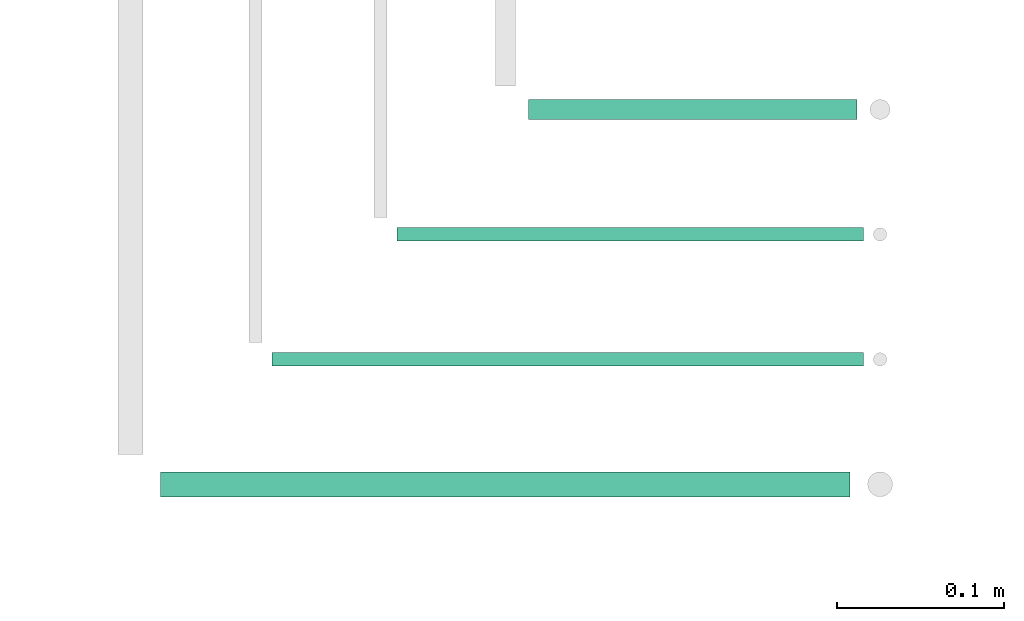
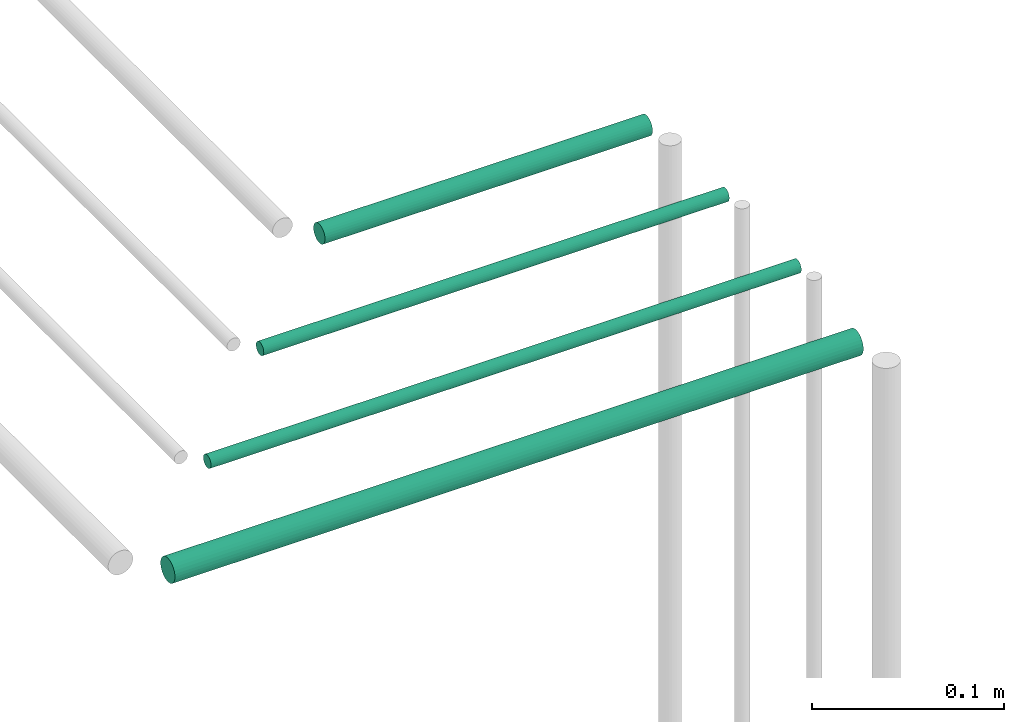
# One storey, part 136 of 331: 4 flow segments.
"""IFC2X3 building model written with IfcOpenShell, lengths in millimetres."""

from ifc_helpers import new_model, entity, si_unit, converted_unit, derived_unit, direction, frame, frame_2d, origin, origin_2d_with_axis, place, context, subcontext, project, spatial, circle, extrude, type_object, element, save


model = new_model("IFC2X3")

# Units and contexts
model_context = context("Model", 3, precision=0.01, world=origin(), true_north=direction((6.12303176911189e-17, 1.0)))
body_context = subcontext(model_context, "Body", "Model", "MODEL_VIEW")
ifc_project = project(units=[si_unit("LENGTHUNIT", "METRE", prefix="MILLI"), si_unit("AREAUNIT", "SQUARE_METRE"), si_unit("VOLUMEUNIT", "CUBIC_METRE"), converted_unit("PLANEANGLEUNIT", "DEGREE", entity("IfcRatioMeasure", 0.0174532925199433), si_unit("PLANEANGLEUNIT", "RADIAN"), dimensions=[0, 0, 0, 0, 0, 0, 0]), si_unit("MASSUNIT", "GRAM", prefix="KILO"), derived_unit("MASSDENSITYUNIT", [(si_unit("MASSUNIT", "GRAM", prefix="KILO"), 1), (si_unit("LENGTHUNIT", "METRE"), -3)]), derived_unit("MOMENTOFINERTIAUNIT", [(si_unit("LENGTHUNIT", "METRE"), 4)]), si_unit("TIMEUNIT", "SECOND"), si_unit("FREQUENCYUNIT", "HERTZ"), si_unit("THERMODYNAMICTEMPERATUREUNIT", "DEGREE_CELSIUS"), derived_unit("THERMALTRANSMITTANCEUNIT", [(si_unit("MASSUNIT", "GRAM", prefix="KILO"), 1), (si_unit("THERMODYNAMICTEMPERATUREUNIT", "KELVIN"), -1), (si_unit("TIMEUNIT", "SECOND"), -3)]), derived_unit("VOLUMETRICFLOWRATEUNIT", [(si_unit("LENGTHUNIT", "METRE"), 3), (si_unit("TIMEUNIT", "SECOND"), -1)]), derived_unit("MASSFLOWRATEUNIT", [(si_unit("MASSUNIT", "GRAM", prefix="KILO"), 1), (si_unit("TIMEUNIT", "SECOND"), -1)]), derived_unit("ROTATIONALFREQUENCYUNIT", [(si_unit("TIMEUNIT", "SECOND"), -1)]), si_unit("ELECTRICCURRENTUNIT", "AMPERE"), si_unit("ELECTRICVOLTAGEUNIT", "VOLT"), si_unit("POWERUNIT", "WATT"), si_unit("FORCEUNIT", "NEWTON", prefix="KILO"), si_unit("ILLUMINANCEUNIT", "LUX"), si_unit("LUMINOUSFLUXUNIT", "LUMEN"), si_unit("LUMINOUSINTENSITYUNIT", "CANDELA"), derived_unit("USERDEFINED", [(si_unit("MASSUNIT", "GRAM", prefix="KILO"), -1), (si_unit("LENGTHUNIT", "METRE"), -2), (si_unit("TIMEUNIT", "SECOND"), 3), (si_unit("LUMINOUSFLUXUNIT", "LUMEN"), 1)]), derived_unit("LINEARVELOCITYUNIT", [(si_unit("LENGTHUNIT", "METRE"), 1), (si_unit("TIMEUNIT", "SECOND"), -1)]), si_unit("PRESSUREUNIT", "PASCAL"), derived_unit("USERDEFINED", [(si_unit("LENGTHUNIT", "METRE"), -2), (si_unit("MASSUNIT", "GRAM", prefix="KILO"), 1), (si_unit("TIMEUNIT", "SECOND"), -2)]), derived_unit("LINEARFORCEUNIT", [(si_unit("MASSUNIT", "GRAM", prefix="KILO"), 1), (si_unit("LENGTHUNIT", "METRE"), 1), (si_unit("TIMEUNIT", "SECOND"), -2), (si_unit("LENGTHUNIT", "METRE"), -1)]), derived_unit("PLANARFORCEUNIT", [(si_unit("MASSUNIT", "GRAM", prefix="KILO"), 1), (si_unit("LENGTHUNIT", "METRE"), 1), (si_unit("TIMEUNIT", "SECOND"), -2), (si_unit("LENGTHUNIT", "METRE"), -2)])], contexts=[model_context])

# Site, building, storey
site_placement = place(None, frame((0.0, -0.00077364408347762, 0.0)))
site = spatial("IfcSite", under=ifc_project, at=site_placement, CompositionType="ELEMENT")
building_placement = place(site_placement, origin())
building = spatial("IfcBuilding", under=site, at=building_placement, CompositionType="ELEMENT")
storey_placement = place(building_placement, origin())
storey = spatial("IfcBuildingStorey", under=building, at=storey_placement, CompositionType="ELEMENT", Elevation=0.0)

# Flow segments
pipe_segment_type = type_object("IfcPipeSegmentType", PredefinedType="NOTDEFINED")
flow_segment_1_placement = place(storey_placement, frame((27685.1806694985, 4927.40472776442, 7242.40472776409)))
element("IfcFlowSegment", 1, at=flow_segment_1_placement, inside=storey, type_object=pipe_segment_type, context=body_context, shape_type="SweptSolid", body=[
    extrude(circle(Radius=6.0, at=origin_2d_with_axis()), frame((0.0, 7.59527223591562, 7.59527223591562), z_axis=(1.0, 0.0, 0.0), x_axis=(0.0, -1.0, 0.0)), (0.0, 0.0, 1.0), 196.893856447563),
])
flow_segment_2_placement = place(storey_placement, frame((27606.1806694985, 4854.40472776442, 7244.40472776409)))
element("IfcFlowSegment", 2, at=flow_segment_2_placement, inside=storey, type_object=pipe_segment_type, context=body_context, shape_type="SweptSolid", body=[
    extrude(circle(Radius=4.0, at=origin_2d_with_axis()), frame((0.0, 5.59527223591661, 5.59527223591607), z_axis=(1.0, 0.0, 0.0), x_axis=(0.0, -1.0, 0.0)), (0.0, 0.0, 1.0), 279.893856447544),
])
flow_segment_3_placement = place(storey_placement, frame((27531.1806694984, 4779.40472776442, 7244.40472776409)))
element("IfcFlowSegment", 3, at=flow_segment_3_placement, inside=storey, type_object=pipe_segment_type, context=body_context, shape_type="SweptSolid", body=[
    extrude(circle(Radius=4.0, at=origin_2d_with_axis()), frame((0.0, 5.59527223591607, 5.59527223591607), z_axis=(1.0, 0.0, 0.0), x_axis=(0.0, -1.0, 0.0)), (0.0, 0.0, 1.0), 354.893856447544),
])
flow_segment_4_placement = place(storey_placement, frame((27464.1806694984, 4700.90472776441, 7240.90472776409)))
element("IfcFlowSegment", 4, at=flow_segment_4_placement, inside=storey, type_object=pipe_segment_type, context=body_context, shape_type="SweptSolid", body=[
    extrude(circle(Radius=7.5, at=frame_2d((1.46187062455283e-11, 0.0), x_axis=(1.0, 0.0))), frame((0.0, 9.09527223593044, 9.09527223591636), z_axis=(1.0, 0.0, 0.0), x_axis=(0.0, 1.0, 0.0)), (0.0, 0.0, 1.0), 413.893856447553),
])

save(model, "model.ifc")
